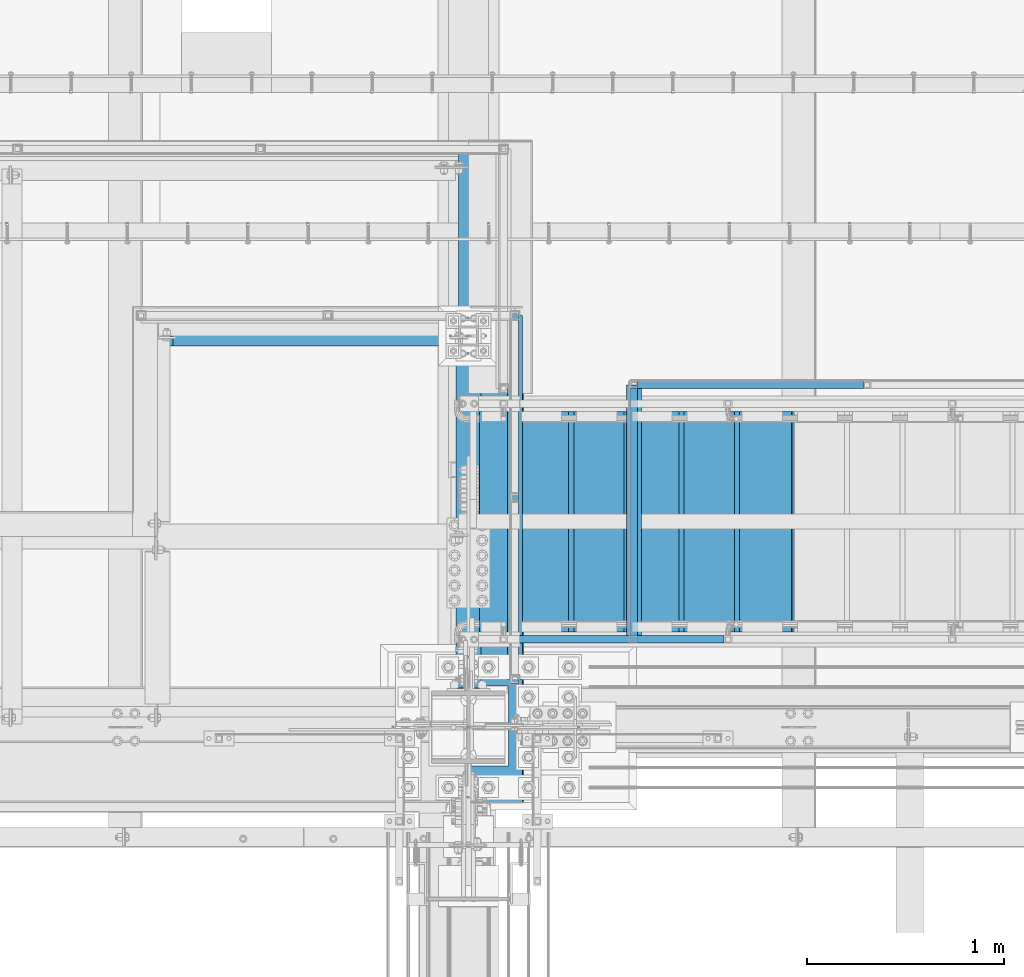
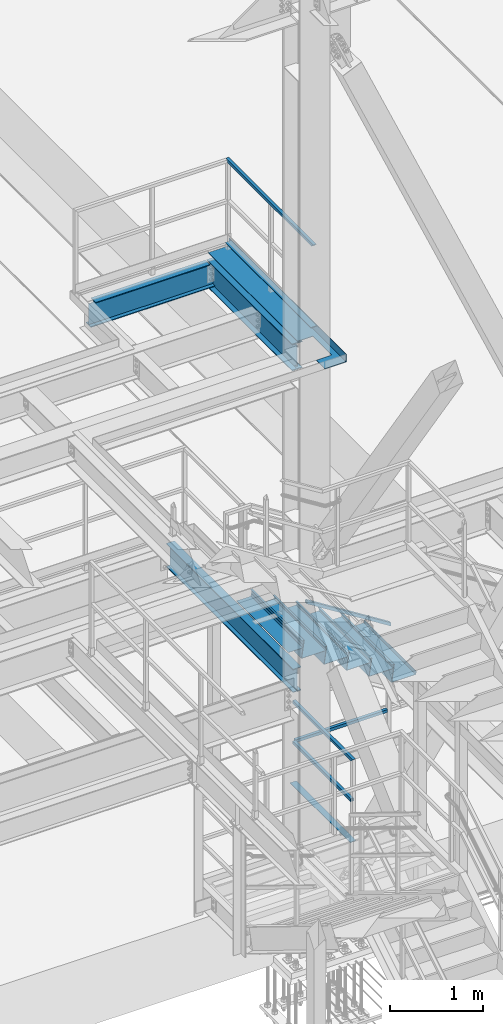
# One storey, part 1786 of 3843: 16 beams, 1 member, 9 elements without a shape of their own.
"""IFC2X3 building model written with IfcOpenShell, lengths in millimetres."""

from ifc_helpers import new_model, si_unit, frame, origin_with_axes, place, context, subcontext, project, spatial, faceted_brep, material, type_object, element, aggregate, save


model = new_model("IFC2X3")

# Units and contexts
model_context = context("Model", 3, precision=1e-05, world=origin_with_axes())
body_context = subcontext(model_context, "Body", "Model", "MODEL_VIEW")
ifc_project = project(units=[si_unit("LENGTHUNIT", "METRE", prefix="MILLI"), si_unit("AREAUNIT", "SQUARE_METRE"), si_unit("VOLUMEUNIT", "CUBIC_METRE"), si_unit("MASSUNIT", "GRAM", prefix="KILO"), si_unit("TIMEUNIT", "SECOND"), si_unit("PLANEANGLEUNIT", "RADIAN"), si_unit("SOLIDANGLEUNIT", "STERADIAN"), si_unit("THERMODYNAMICTEMPERATUREUNIT", "DEGREE_CELSIUS"), si_unit("LUMINOUSINTENSITYUNIT", "LUMEN")], contexts=[model_context])

# Site, building, storey
site_placement = place(None, origin_with_axes())
site = spatial("IfcSite", under=ifc_project, at=site_placement, CompositionType="ELEMENT")
building_placement = place(site_placement, origin_with_axes())
building = spatial("IfcBuilding", under=site, at=building_placement, Name="Undefined", CompositionType="ELEMENT")
storey_placement = place(building_placement, origin_with_axes())
storey = spatial("IfcBuildingStorey", under=building, at=storey_placement, Name="Undefined", CompositionType="ELEMENT", Elevation=0.0)

# Assembly, beam
assembly_1_placement = place(storey_placement, origin_with_axes())
assembly_1 = element("IfcElementAssembly", 1, at=assembly_1_placement, inside=storey, Name="RAIL", AssemblyPlace="NOTDEFINED", PredefinedType="RIGID_FRAME")
ifc_material_1 = material()
beam_type_1 = type_object("IfcBeamType", Name="HSS1-1/2X1-1/2X1/4", PredefinedType="NOTDEFINED")
beam_1_placement = place(assembly_1_placement, frame((56165.7500122071, 27720.9247854388, 38633.3999983618), z_axis=(0.0, 0.0, -1.0), x_axis=(0.0, -1.0, 0.0)))
beam_1 = element("IfcBeam", 2, at=beam_1_placement, type_object=beam_type_1, material=ifc_material_1, Name="RAIL", ObjectType="HSS1-1/2X1-1/2X1/4", context=body_context, shape_type="Brep", body=[
    faceted_brep([(6.34999999999854, 12.6999993299978, -12.6999993299978), (6.34999999999854, -12.6999993299978, -12.6999993299978), (1876.42478706376, -12.6999993299978, -12.6999993299978), (1876.42478706376, 12.6999993299978, -12.6999993299978), (31.7500007135677, -12.6999993300014, 12.6999993299978), (1851.02478840376, -12.6999993299978, 12.6999993299978), (31.7500007135677, 12.6999993300014, 12.6999993299978), (1851.02478840376, 12.6999993299978, 12.6999993299978), (0.0, 19.0500000000029, -19.0499999999993), (38.0999984699883, 19.0499992350015, 19.0499992350015), (1844.67478849876, 19.0499992350015, 19.0499992350015), (1882.77478696876, 19.0499992350015, -19.0499992350015), (38.0999984699883, -19.0499992350015, 19.0499992350015), (1844.67478849876, -19.0499992350015, 19.0499992350015), (0.0, -19.0499992350015, -19.0499992350015), (1882.77478696876, -19.0499992350015, -19.0499992350015)], [[[0, 1, 2, 3]], [[1, 4, 5, 2]], [[4, 6, 7, 5]], [[6, 0, 3, 7]], [[8, 9, 10, 11]], [[9, 12, 13, 10]], [[12, 14, 15, 13]], [[14, 8, 11, 15]], [[13, 15, 11, 10], [5, 7, 3, 2]], [[14, 12, 9, 8], [6, 4, 1, 0]]]),
])
aggregate(assembly_1, [beam_1])

# Assembly, beams
assembly_2_placement = place(storey_placement, origin_with_axes())
assembly_2 = element("IfcElementAssembly", 3, at=assembly_2_placement, inside=storey, Name="RAIL", AssemblyPlace="NOTDEFINED", PredefinedType="RIGID_FRAME")
beam_2_placement = place(assembly_2_placement, frame((56769.0000000085, 26060.4000000594, 31013.3999999739), z_axis=(0.0, 0.0, 1.0), x_axis=(0.0, 1.0, 0.0)))
beam_2 = element("IfcBeam", 4, at=beam_2_placement, type_object=beam_type_1, material=ifc_material_1, Name="RAIL", ObjectType="HSS1-1/2X1-1/2X1/4", context=body_context, shape_type="Brep", body=[
    faceted_brep([(1269.99999999064, -19.0499999999956, 19.0499992350015), (1269.99999999064, -19.0499992350015, -19.0499992350015), (1269.99999999064, 19.0499992350015, -19.0499992350015), (1269.99999999064, 19.0499992350015, 19.0499992350015), (1269.99999999064, -12.6999993299978, 12.6999993300014), (1269.99999999064, 12.6999993299978, 12.6999993300014), (1269.99999999064, 12.6999993299978, -12.6999993300014), (1269.99999999064, -12.6999993299978, -12.6999993300014), (19.0499992350015, 19.0499992350015, -19.0499992350015), (19.0499992350015, 19.0499992350015, 19.0499992350015), (19.0499992350015, -19.0499992350015, 19.0499992350015), (19.0499992350015, -19.0499992350015, -19.0499992350015), (19.0499992350015, 12.6999993299978, 12.6999993299978), (19.0499992350015, -12.6999993299978, 12.6999993299978), (19.0499992350015, -12.6999993299978, -12.6999993299978), (19.0499992350015, 12.6999993299978, -12.6999993299978)], [[[0, 1, 2, 3], [4, 5, 6, 7]], [[8, 9, 3, 2]], [[9, 10, 0, 3]], [[10, 11, 1, 0]], [[11, 8, 2, 1]], [[11, 10, 9, 8], [12, 13, 14, 15]], [[14, 13, 4, 7]], [[15, 14, 7, 6]], [[12, 15, 6, 5]], [[13, 12, 5, 4]]]),
])
beam_3_placement = place(assembly_2_placement, frame((56769.0000000085, 27368.499999285, 31546.7999999739), z_axis=(0.0, 0.0, -1.0), x_axis=(0.0, -1.0, 0.0)))
beam_3 = element("IfcBeam", 5, at=beam_3_placement, type_object=beam_type_1, material=ifc_material_1, Name="RAIL", ObjectType="HSS1-1/2X1-1/2X1/4", context=body_context, shape_type="Brep", body=[
    faceted_brep([(38.0999984699883, 12.6999993299978, -12.6999993300014), (38.0999984699883, -12.6999993299978, -12.6999993300014), (1320.79999855565, -12.6999993299978, -12.6999993300014), (1320.79999855565, 12.6999993299978, -12.6999993300014), (38.0999984699883, -12.6999993299978, 12.6999993300014), (1295.39999989564, -12.6999993299978, 12.6999993300014), (38.0999984699883, 12.6999993299978, 12.6999993300014), (1295.39999989564, 12.6999993299978, 12.6999993300014), (38.0999984699883, 19.0499992350015, -19.0499992350015), (38.0999984699883, 19.0499992350015, 19.0499992350015), (1289.04999999064, 19.0499992350015, 19.0499992350015), (1327.14999846065, 19.0499992350015, -19.0499992350015), (38.0999984699883, -19.0499992350015, 19.0499992350015), (1289.04999999064, -19.0499992350015, 19.0499992350015), (38.0999984699883, -19.0499992350015, -19.0499992350015), (1327.14999846065, -19.0499992350015, -19.0499992350015)], [[[0, 1, 2, 3]], [[1, 4, 5, 2]], [[4, 6, 7, 5]], [[6, 0, 3, 7]], [[8, 9, 10, 11]], [[9, 12, 13, 10]], [[12, 14, 15, 13]], [[14, 8, 11, 15]], [[13, 15, 11, 10], [5, 7, 3, 2]], [[14, 12, 9, 8], [6, 4, 1, 0]]]),
])
beam_4_placement = place(assembly_2_placement, frame((57950.1000000016, 27349.4500000502, 31013.3999999739), z_axis=(0.0, 0.0, 1.0), x_axis=(-1.0, 0.0, 0.0)))
beam_4 = element("IfcBeam", 6, at=beam_4_placement, type_object=beam_type_1, material=ifc_material_1, Name="RAIL", ObjectType="HSS1-1/2X1-1/2X1/4", context=body_context, shape_type="Brep", body=[
    faceted_brep([(1162.04999999311, -19.0499999997628, 19.0499992350015), (1162.04999999311, -19.0499992350015, -19.0499992350015), (1162.04999999311, 19.0499992350015, -19.0499992350015), (1162.04999999311, 19.0499992350015, 19.0499992350015), (1162.04999999311, -12.6999993300014, 12.6999993300014), (1162.04999999311, 12.6999993300014, 12.6999993300014), (1162.04999999311, 12.6999993300014, -12.6999993300014), (1162.04999999311, -12.6999993300014, -12.6999993300014), (19.0499992350015, 19.0499992350015, -19.0499992350015), (19.0499992350015, 19.0499992350015, 19.0499992350015), (19.0499992350015, -19.0499992350015, 19.0499992350015), (19.0499992350015, -19.0499992350015, -19.0499992350015), (19.0499992350015, 12.6999993299978, 12.6999993299978), (19.0499992350015, -12.6999993299978, 12.6999993299978), (19.0499992350015, -12.6999993299978, -12.6999993299978), (19.0499992350015, 12.6999993299978, -12.6999993299978)], [[[0, 1, 2, 3], [4, 5, 6, 7]], [[8, 9, 3, 2]], [[9, 10, 0, 3]], [[10, 11, 1, 0]], [[11, 8, 2, 1]], [[11, 10, 9, 8], [12, 13, 14, 15]], [[14, 13, 4, 7]], [[15, 14, 7, 6]], [[12, 15, 6, 5]], [[13, 12, 5, 4]]]),
])
aggregate(assembly_2, [beam_2, beam_3, beam_4])

# Assembly, member
assembly_3_placement = place(storey_placement, origin_with_axes())
assembly_3 = element("IfcElementAssembly", 7, at=assembly_3_placement, inside=storey, Name="RAIL", AssemblyPlace="NOTDEFINED", PredefinedType="RIGID_FRAME")
member_type = type_object("IfcMemberType", Name="HSS1-1/2X1-1/2X1/4", PredefinedType="NOTDEFINED")
member_placement = place(assembly_3_placement, frame((57245.2499999772, 26060.40000005, 33163.9934658526), z_axis=(0.533450437959022, 0.0, 0.845831324935018), x_axis=(-0.845831324935018, 0.0, 0.533450437959022)))
member = element("IfcMember", 8, at=member_placement, type_object=member_type, material=ifc_material_1, Name="RAIL", ObjectType="HSS1-1/2X1-1/2X1/4", context=body_context, shape_type="Brep", body=[
    faceted_brep([(34.5367091819608, -19.0500003825, 19.0499992349214), (34.5367091819608, 19.0499992350015, 19.0499992349214), (10.507732870894, 19.0499992350015, -19.049999235016), (10.507732870894, -19.0499992350015, -19.049999235016), (30.5318796958745, -12.6999993300014, 12.699999329925), (14.5125623569802, -12.6999993300014, -12.6999993300269), (14.5125623569802, 12.6999993300014, -12.6999993300269), (30.5318796958745, 12.6999993300014, 12.699999329925), (1248.23146424039, 19.0499992350015, -19.0499992375117), (1248.23146424039, -19.0499992350015, -19.0499992375117), (1259.2424708534, -19.0499992350015, 19.0499992324476), (1259.2424708534, 19.0499992350015, 19.0499992324476), (1257.40730303832, -12.6999993300014, 12.6999993274512), (1257.40730303832, 12.6999993300014, 12.6999993274512), (1250.06663205547, 12.6999993300014, -12.6999993325153), (1250.06663205547, -12.6999993300014, -12.6999993325153)], [[[0, 1, 2, 3], [4, 5, 6, 7]], [[8, 9, 3, 2]], [[9, 10, 0, 3]], [[10, 11, 1, 0]], [[11, 8, 2, 1]], [[10, 9, 8, 11], [12, 13, 14, 15]], [[13, 12, 4, 7]], [[14, 13, 7, 6]], [[15, 14, 6, 5]], [[12, 15, 5, 4]]]),
])
aggregate(assembly_3, [member])

# Assembly, beam
assembly_4_placement = place(storey_placement, origin_with_axes())
assembly_4 = element("IfcElementAssembly", 9, at=assembly_4_placement, inside=storey, Name="ref.", AssemblyPlace="NOTDEFINED", PredefinedType="RIGID_FRAME")
ifc_material_2 = material(Name="STEEL/Steel_Undefined")
beam_type_2 = type_object("IfcBeamType", PredefinedType="NOTDEFINED")
beam_5_placement = place(assembly_4_placement, frame((56165.750012207, 25857.199997705, 37563.4249983618), z_axis=(1.0, 0.0, 0.0), x_axis=(0.0, 1.0, 0.0)))
beam_5 = element("IfcBeam", 10, at=beam_5_placement, type_object=beam_type_2, material=ifc_material_2, Name="ref.", context=body_context, shape_type="Brep", body=[
    faceted_brep([(0.0, 3.17500000000291, -38.0999999999985), (0.0, 3.17500000000291, 38.0999999999985), (1844.67478849919, 3.17500000000291, 38.0999999999985), (1844.67478849919, 3.17500000000291, -38.0999999999985), (0.0, -3.17500000000291, 38.0999999999985), (1844.67478849919, -3.17500000000291, 38.0999999999985), (0.0, -3.17500000000291, -38.0999999999985), (1844.67478849919, -3.17500000000291, -38.0999999999985)], [[[0, 1, 2, 3]], [[1, 4, 5, 2]], [[4, 6, 7, 5]], [[6, 0, 3, 7]], [[5, 7, 3, 2]], [[6, 4, 1, 0]]]),
])
aggregate(assembly_4, [beam_5])

assembly_5_placement = place(storey_placement, origin_with_axes())
assembly_5 = element("IfcElementAssembly", 11, at=assembly_5_placement, inside=storey, Name="ref.", AssemblyPlace="NOTDEFINED", PredefinedType="RIGID_FRAME")
beam_6_placement = place(assembly_5_placement, frame((56769.0000000085, 27349.45000005, 30476.8249999739), z_axis=(1.0, 0.0, 0.0), x_axis=(0.0, -1.0, 0.0)))
beam_6 = element("IfcBeam", 12, at=beam_6_placement, type_object=beam_type_2, material=ifc_material_2, Name="ref.", context=body_context, shape_type="Brep", body=[
    faceted_brep([(0.0, 3.17500000000291, -38.0999999999985), (0.0, 3.17500000000291, 38.0999999999985), (1289.04999999063, 3.17499999999927, 38.0999999999985), (1289.04999999063, 3.17499999999927, -38.0999999999985), (0.0, -3.17500000000291, 38.0999999999985), (1289.04999999063, -3.17499999999927, 38.0999999999985), (0.0, -3.17500000000291, -38.0999999999985), (1289.04999999063, -3.17499999999927, -38.0999999999985)], [[[0, 1, 2, 3]], [[1, 4, 5, 2]], [[4, 6, 7, 5]], [[6, 0, 3, 7]], [[5, 7, 3, 2]], [[6, 4, 1, 0]]]),
])
aggregate(assembly_5, [beam_6])

assembly_6_placement = place(storey_placement, origin_with_axes())
assembly_6 = element("IfcElementAssembly", 13, at=assembly_6_placement, inside=storey, Name="STAIR", AssemblyPlace="NOTDEFINED", PredefinedType="RIGID_FRAME")
ifc_material_3 = material(Name="STEEL/ASTM A1011")
beam_type_3 = type_object("IfcBeamType", PredefinedType="NOTDEFINED")
beam_7_placement = place(assembly_6_placement, frame((55987.9499999695, 26657.3000000416, 33205.7375000177), z_axis=(0.0, 1.0, 0.0), x_axis=(1.0, 0.0, 0.0)))
beam_7 = element("IfcBeam", 14, at=beam_7_placement, type_object=beam_type_3, material=ifc_material_3, Name="TREAD", context=body_context, shape_type="Brep", body=[
    faceted_brep([(0.0, -1.58750000000146, -558.799999999999), (0.0, -1.58750000000146, 558.799999999999), (0.0, 1.58750000000146, 558.799999999999), (0.0, 1.58750000000146, -558.799999999999), (179.41899566666, 1.58750000000146, 558.799999999999), (179.41899566666, 1.58750000000146, -558.799999999999), (176.704640751166, -1.58750000000146, -558.799999999999), (176.704640751166, -1.58750000000146, 558.799999999999), (185.276740617643, -35.6290960190308, 558.799999999999), (185.276740617643, -35.6290960190308, -558.799999999999), (182.140352618517, -36.1227510797107, 558.799999999999), (182.140352618517, -36.1227510797107, -558.799999999999)], [[[0, 1, 2, 3]], [[3, 2, 4, 5]], [[1, 0, 6, 7]], [[5, 4, 8, 9]], [[4, 2, 1, 7, 10, 8]], [[7, 6, 11, 10]], [[6, 0, 3, 5, 9, 11]], [[10, 11, 9, 8]]]),
])

assembly_7_placement = place(storey_placement, origin_with_axes())
assembly_7 = element("IfcElementAssembly", 15, at=assembly_7_placement, inside=storey, Name="BEAM", AssemblyPlace="NOTDEFINED", PredefinedType="RIGID_FRAME")
ifc_material_4 = material(Name="STEEL/A992")
beam_type_4 = type_object("IfcBeamType", Name="W12X19", PredefinedType="NOTDEFINED")
beam_8_placement = place(assembly_7_placement, frame((54356.0, 27597.1, 37311.0125), z_axis=(0.0, 0.0, 1.0), x_axis=(1.0, 0.0, 0.0)))
beam_8 = element("IfcBeam", 16, at=beam_8_placement, type_object=beam_type_4, material=ifc_material_4, Name="BEAM", ObjectType="W12X19", context=body_context, shape_type="Brep", body=[
    faceted_brep([(66.6750001907276, -3.17500000000291, 128.587500000001), (66.6750001907276, 3.17500000000291, 128.587500000001), (15.8750000000146, 3.17500000000291, 128.587500001042), (15.8750000000146, -3.17500000000291, 128.587500001042), (71.535079708774, -3.17500000000291, 129.554229922593), (71.535079708774, 3.17500000000291, 129.554229922593), (75.6552561769277, -3.17500000000291, 132.307243823067), (75.6552561769277, 3.17500000000291, 132.307243823067), (78.4082700774052, -3.17500000000291, 136.42742029122), (78.4082700774052, 3.17500000000291, 136.42742029122), (79.3749999999927, -3.17500000000291, 141.287499809267), (79.3749999999927, 3.17500000000291, 141.287499809267), (79.3750000000073, -50.7999999999993, 153.891067210468), (79.3749999999927, 50.8000000000029, 153.987500000003), (79.3749999999927, 50.8000000000029, 144.462500000001), (79.3749999999927, 3.17500000000291, 144.462500000001), (79.3749999999927, -3.17500000000291, 144.462500000001), (79.3749999999927, -50.8000000000029, 144.462500000001), (15.8749999999927, -3.17500000000291, -144.462500000001), (15.8749999999927, -50.8000000000029, -144.462500000001), (1558.925, -50.7999999999993, -144.462500000001), (1558.925, -3.17499999999927, -144.462500000001), (15.8749999999927, -50.8000000000029, -153.987500000003), (1558.925, -50.7999999999993, -153.987500000003), (15.8749999999927, 50.8000000000029, -153.987500000003), (1558.925, 50.7999999999993, -153.987500000003), (15.8749999999927, 50.8000000000029, -144.462500000001), (1558.925, 50.7999999999993, -144.462500000001), (15.8749999999927, 3.17500000000291, -144.462500000001), (1558.925, 3.17499999999927, -144.462500000001), (1558.925, -3.17499999999927, 115.887499999997), (1558.925, -3.17499999999927, -114.712500000001), (1558.925, 3.17499999999927, 128.587500000001), (1558.925, -3.17499999999927, 128.587500000001), (1508.12499980927, 3.17499999999927, 128.587500000001), (1508.12499980927, -3.17499999999927, 128.587500000001), (1503.26492029122, 3.17499999999927, 129.554229922593), (1503.26492029122, -3.17499999999927, 129.554229922593), (1499.14474382307, 3.17499999999927, 132.307243823067), (1499.14474382307, -3.17499999999927, 132.307243823067), (1496.39172992259, 3.17499999999927, 136.42742029122), (1496.39172992259, -3.17499999999927, 136.42742029122), (1495.425, 3.17499999999927, 141.287499809267), (1495.425, -3.17499999999927, 141.287499809267), (1495.425, -50.7999999999993, 153.987500000003), (1495.425, -50.7999999999993, 144.462500000001), (1495.425, -3.17499999999927, 144.462500000001), (1495.425, 3.17499999999927, 144.462500000001), (1495.425, 50.7999999999993, 144.462500000001), (1495.425, 50.7999999999993, 153.987500000003), (15.8750000000073, -3.17499999999927, 115.887499999997), (15.8750000000073, -3.17499999999927, -114.712500000001)], [[[0, 1, 2, 3]], [[4, 5, 1, 0]], [[6, 7, 5, 4]], [[8, 9, 7, 6]], [[10, 11, 9, 8]], [[12, 13, 14, 15, 11, 10, 16, 17]], [[18, 19, 20, 21]], [[19, 22, 23, 20]], [[22, 24, 25, 23]], [[24, 26, 27, 25]], [[26, 28, 29, 27]], [[30, 31, 21, 20, 23, 25, 27, 29, 32, 33]], [[33, 32, 34, 35]], [[35, 34, 36, 37]], [[37, 36, 38, 39]], [[39, 38, 40, 41]], [[41, 40, 42, 43]], [[44, 45, 46, 43, 42, 47, 48, 49]], [[45, 44, 12, 17]], [[46, 45, 17, 16]], [[8, 6, 4, 0, 3, 50, 51, 18, 21, 31, 30, 33, 35, 37, 39, 41, 43, 46, 16, 10]], [[28, 26, 24, 22, 19, 18, 51, 50, 3, 2]], [[47, 42, 40, 38, 36, 34, 32, 29, 28, 2, 1, 5, 7, 9, 11, 15]], [[48, 47, 15, 14]], [[49, 48, 14, 13]], [[44, 49, 13, 12]]]),
])
aggregate(assembly_7, [beam_8])

assembly_8_placement = place(storey_placement, origin_with_axes())
assembly_8 = element("IfcElementAssembly", 17, at=assembly_8_placement, inside=storey, Name="BEAM", AssemblyPlace="NOTDEFINED", PredefinedType="RIGID_FRAME")
beam_9_placement = place(assembly_8_placement, frame((55930.8, 25615.8999999464, 33043.8124999995), z_axis=(0.0, 0.0, 1.0), x_axis=(0.0, 1.0, 0.0)))
beam_9 = element("IfcBeam", 18, at=beam_9_placement, type_object=beam_type_4, material=ifc_material_4, Name="BEAM", ObjectType="W12X19", context=body_context, shape_type="Brep", body=[
    faceted_brep([(196.849999999973, -50.8000000000029, -144.462500000001), (196.849999999973, -50.8000000000029, -153.987500000003), (2921.00000005052, -50.8000000000029, -153.987500000003), (2921.00000005052, -50.8000000000029, -144.462500000001), (196.849999999973, -3.17500000000291, -144.462500000001), (2921.00000005052, -3.17500000000291, -144.462500000001), (196.849999999973, -3.17500000000291, 144.462500000001), (2921.00000005052, -3.17500000000291, 144.462500000001), (196.849999999973, -50.8000000000029, 144.462500000001), (2921.00000005052, -50.8000000000029, 144.462500000001), (196.849999999973, -50.8000000000029, 153.987500000003), (2921.00000005052, -50.8000000000029, 153.987500000003), (196.849999999973, 50.8000000000029, 153.987500000003), (2921.00000005052, 50.8000000000029, 153.987500000003), (196.849999999973, 50.8000000000029, 144.462500000001), (2921.00000005052, 50.8000000000029, 144.462500000001), (196.849999999973, 3.17500000000291, 144.462500000001), (2921.00000005052, 3.17500000000291, 144.462500000001), (196.849999999973, 3.17500000000291, -144.462500000001), (2921.00000005052, 3.17500000000291, -144.462500000001), (196.849999999973, 50.8000000000029, -144.462500000001), (2921.00000005052, 50.8000000000029, -144.462500000001), (196.849999999973, 50.8000000000029, -153.987500000003), (2921.00000005052, 50.8000000000029, -153.987500000003)], [[[0, 1, 2, 3]], [[4, 0, 3, 5]], [[6, 4, 5, 7]], [[8, 6, 7, 9]], [[10, 8, 9, 11]], [[12, 10, 11, 13]], [[14, 12, 13, 15]], [[16, 14, 15, 17]], [[18, 16, 17, 19]], [[20, 18, 19, 21]], [[1, 0, 4, 6, 8, 10, 12, 14, 16, 18, 20, 22]], [[1, 22, 23, 2]], [[19, 17, 15, 13, 11, 9, 7, 5, 3, 2, 23, 21]], [[22, 20, 21, 23]]]),
])
aggregate(assembly_8, [beam_9])

# Beam
beam_type_5 = type_object("IfcBeamType", PredefinedType="NOTDEFINED")
beam_10_placement = place(assembly_6_placement, frame((56159.4000000094, 26657.3000000521, 33297.812499978), z_axis=(0.0, 1.0, 0.0), x_axis=(1.0, 0.0, 0.0)))
beam_10 = element("IfcBeam", 19, at=beam_10_placement, type_object=beam_type_5, material=ifc_material_3, Name="TREAD", context=body_context, shape_type="Brep", body=[
    faceted_brep([(0.0, -1.58750000000146, -558.799999999999), (0.0, -1.58750000000146, 558.799999999999), (0.0, 1.58750000000146, 558.799999999999), (0.0, 1.58750000000146, -558.799999999999), (21.7345275870466, 1.58750000000146, 558.799999999999), (21.7345275870466, 1.58750000000146, -558.799999999999), (25.3999999999942, -1.58750000000146, -558.799999999999), (25.3999999999942, -1.58750000000146, 558.799999999999), (-10.9879949354727, 228.599999999999, 558.799999999999), (-10.9879949354727, 228.599999999999, -558.799999999999), (-7.32252251826139, 225.424999999996, -558.799999999999), (-7.32252251826139, 225.424999999996, 558.799999999999), (293.812005064523, 228.599999999999, 558.799999999999), (293.812005064523, 228.599999999999, -558.799999999999), (291.061847962628, 225.424999999996, -558.799999999999), (291.061847962628, 225.424999999996, 558.799999999999), (299.640080752673, 188.167724913437, 558.799999999999), (299.640080752673, 188.167724913437, -558.799999999999), (296.49755982936, 187.714748924496, 558.799999999999), (296.49755982936, 187.714748924496, -558.799999999999)], [[[0, 1, 2, 3]], [[3, 2, 4, 5]], [[1, 0, 6, 7]], [[5, 4, 8, 9]], [[7, 6, 10, 11]], [[9, 8, 12, 13]], [[11, 10, 14, 15]], [[13, 12, 16, 17]], [[12, 8, 4, 2, 1, 7, 11, 15, 18, 16]], [[15, 14, 19, 18]], [[14, 10, 6, 0, 3, 5, 9, 13, 17, 19]], [[18, 19, 17, 16]]]),
])

beam_11_placement = place(assembly_6_placement, frame((56438.8000000093, 26657.30000005, 33121.599999978), z_axis=(0.0, 1.0, 0.0), x_axis=(1.0, 0.0, 0.0)))
beam_11 = element("IfcBeam", 20, at=beam_11_placement, type_object=beam_type_5, material=ifc_material_3, Name="TREAD", context=body_context, shape_type="Brep", body=[
    faceted_brep([(0.0, -1.58750000000146, -558.799999999999), (0.0, -1.58750000000146, 558.799999999999), (0.0, 1.58750000000146, 558.799999999999), (0.0, 1.58750000000146, -558.799999999999), (21.7345275870466, 1.58750000000146, 558.799999999999), (21.7345275870466, 1.58750000000146, -558.799999999999), (25.3999999999942, -1.58750000000146, -558.799999999999), (25.3999999999942, -1.58750000000146, 558.799999999999), (-10.9879949354727, 228.599999999999, 558.799999999999), (-10.9879949354727, 228.599999999999, -558.799999999999), (-7.32252251826139, 225.424999999996, -558.799999999999), (-7.32252251826139, 225.424999999996, 558.799999999999), (293.812005064523, 228.599999999999, 558.799999999999), (293.812005064523, 228.599999999999, -558.799999999999), (291.061847962628, 225.424999999996, -558.799999999999), (291.061847962628, 225.424999999996, 558.799999999999), (299.640080752673, 188.167724913437, 558.799999999999), (299.640080752673, 188.167724913437, -558.799999999999), (296.49755982936, 187.714748924496, 558.799999999999), (296.49755982936, 187.714748924496, -558.799999999999)], [[[0, 1, 2, 3]], [[3, 2, 4, 5]], [[1, 0, 6, 7]], [[5, 4, 8, 9]], [[7, 6, 10, 11]], [[9, 8, 12, 13]], [[11, 10, 14, 15]], [[13, 12, 16, 17]], [[12, 8, 4, 2, 1, 7, 11, 15, 18, 16]], [[15, 14, 19, 18]], [[14, 10, 6, 0, 3, 5, 9, 13, 17, 19]], [[18, 19, 17, 16]]]),
])

beam_12_placement = place(assembly_6_placement, frame((56718.2000000094, 26657.300000048, 32945.387499978), z_axis=(0.0, 1.0, 0.0), x_axis=(1.0, 0.0, 0.0)))
beam_12 = element("IfcBeam", 21, at=beam_12_placement, type_object=beam_type_5, material=ifc_material_3, Name="TREAD", context=body_context, shape_type="Brep", body=[
    faceted_brep([(0.0, -1.58750000000146, -558.799999999999), (0.0, -1.58750000000146, 558.799999999999), (0.0, 1.58750000000146, 558.799999999999), (0.0, 1.58750000000146, -558.799999999999), (21.7345275870466, 1.58750000000146, 558.799999999999), (21.7345275870466, 1.58750000000146, -558.799999999999), (25.3999999999942, -1.58750000000146, -558.799999999999), (25.3999999999942, -1.58750000000146, 558.799999999999), (-10.9879949354727, 228.599999999999, 558.799999999999), (-10.9879949354727, 228.599999999999, -558.799999999999), (-7.32252251826139, 225.424999999996, -558.799999999999), (-7.32252251826139, 225.424999999996, 558.799999999999), (293.812005064523, 228.599999999999, 558.799999999999), (293.812005064523, 228.599999999999, -558.799999999999), (291.061847962628, 225.424999999996, -558.799999999999), (291.061847962628, 225.424999999996, 558.799999999999), (299.640080752673, 188.167724913437, 558.799999999999), (299.640080752673, 188.167724913437, -558.799999999999), (296.49755982936, 187.714748924496, 558.799999999999), (296.49755982936, 187.714748924496, -558.799999999999)], [[[0, 1, 2, 3]], [[3, 2, 4, 5]], [[1, 0, 6, 7]], [[5, 4, 8, 9]], [[7, 6, 10, 11]], [[9, 8, 12, 13]], [[11, 10, 14, 15]], [[13, 12, 16, 17]], [[12, 8, 4, 2, 1, 7, 11, 15, 18, 16]], [[15, 14, 19, 18]], [[14, 10, 6, 0, 3, 5, 9, 13, 17, 19]], [[18, 19, 17, 16]]]),
])

beam_13_placement = place(assembly_6_placement, frame((56997.6000000095, 26657.3000000451, 32769.1749999779), z_axis=(0.0, 1.0, 0.0), x_axis=(1.0, 0.0, 0.0)))
beam_13 = element("IfcBeam", 22, at=beam_13_placement, type_object=beam_type_5, material=ifc_material_3, Name="TREAD", context=body_context, shape_type="Brep", body=[
    faceted_brep([(0.0, -1.58750000000146, -558.799999999999), (0.0, -1.58750000000146, 558.799999999999), (0.0, 1.58750000000146, 558.799999999999), (0.0, 1.58750000000146, -558.799999999999), (21.7345275870466, 1.58750000000146, 558.799999999999), (21.7345275870466, 1.58750000000146, -558.799999999999), (25.3999999999942, -1.58750000000146, -558.799999999999), (25.3999999999942, -1.58750000000146, 558.799999999999), (-10.9879949354727, 228.599999999999, 558.799999999999), (-10.9879949354727, 228.599999999999, -558.799999999999), (-7.32252251826139, 225.424999999996, -558.799999999999), (-7.32252251826139, 225.424999999996, 558.799999999999), (293.812005064523, 228.599999999999, 558.799999999999), (293.812005064523, 228.599999999999, -558.799999999999), (291.061847962628, 225.424999999996, -558.799999999999), (291.061847962628, 225.424999999996, 558.799999999999), (299.640080752673, 188.167724913437, 558.799999999999), (299.640080752673, 188.167724913437, -558.799999999999), (296.49755982936, 187.714748924496, 558.799999999999), (296.49755982936, 187.714748924496, -558.799999999999)], [[[0, 1, 2, 3]], [[3, 2, 4, 5]], [[1, 0, 6, 7]], [[5, 4, 8, 9]], [[7, 6, 10, 11]], [[9, 8, 12, 13]], [[11, 10, 14, 15]], [[13, 12, 16, 17]], [[12, 8, 4, 2, 1, 7, 11, 15, 18, 16]], [[15, 14, 19, 18]], [[14, 10, 6, 0, 3, 5, 9, 13, 17, 19]], [[18, 19, 17, 16]]]),
])

beam_14_placement = place(assembly_6_placement, frame((57277.0000000107, 26657.3000000437, 32592.9624999799), z_axis=(0.0, 1.0, 0.0), x_axis=(1.0, 0.0, 0.0)))
beam_14 = element("IfcBeam", 23, at=beam_14_placement, type_object=beam_type_5, material=ifc_material_3, Name="TREAD", context=body_context, shape_type="Brep", body=[
    faceted_brep([(0.0, -1.58750000000146, -558.799999999999), (0.0, -1.58750000000146, 558.799999999999), (0.0, 1.58750000000146, 558.799999999999), (0.0, 1.58750000000146, -558.799999999999), (21.7345275870466, 1.58750000000146, 558.799999999999), (21.7345275870466, 1.58750000000146, -558.799999999999), (25.3999999999942, -1.58750000000146, -558.799999999999), (25.3999999999942, -1.58750000000146, 558.799999999999), (-10.9879949354727, 228.599999999999, 558.799999999999), (-10.9879949354727, 228.599999999999, -558.799999999999), (-7.32252251826139, 225.424999999996, -558.799999999999), (-7.32252251826139, 225.424999999996, 558.799999999999), (293.812005064523, 228.599999999999, 558.799999999999), (293.812005064523, 228.599999999999, -558.799999999999), (291.061847962628, 225.424999999996, -558.799999999999), (291.061847962628, 225.424999999996, 558.799999999999), (299.640080752673, 188.167724913437, 558.799999999999), (299.640080752673, 188.167724913437, -558.799999999999), (296.49755982936, 187.714748924496, 558.799999999999), (296.49755982936, 187.714748924496, -558.799999999999)], [[[0, 1, 2, 3]], [[3, 2, 4, 5]], [[1, 0, 6, 7]], [[5, 4, 8, 9]], [[7, 6, 10, 11]], [[9, 8, 12, 13]], [[11, 10, 14, 15]], [[13, 12, 16, 17]], [[12, 8, 4, 2, 1, 7, 11, 15, 18, 16]], [[15, 14, 19, 18]], [[14, 10, 6, 0, 3, 5, 9, 13, 17, 19]], [[18, 19, 17, 16]]]),
])

aggregate(assembly_6, [beam_7, beam_10, beam_11, beam_12, beam_13, beam_14])

# Assembly, beams
assembly_9_placement = place(storey_placement, origin_with_axes())
assembly_9 = element("IfcElementAssembly", 24, at=assembly_9_placement, inside=storey, Name="BEAM", AssemblyPlace="NOTDEFINED", PredefinedType="RIGID_FRAME")
ifc_material_5 = material(Name="STEEL/A36")
beam_type_6 = type_object("IfcBeamType", PredefinedType="NOTDEFINED")
beam_15_placement = place(assembly_9_placement, frame((55943.5, 26490.4977862042, 37468.175), z_axis=(0.0, -1.0, 0.0), x_axis=(1.0, 0.0, 0.0)))
beam_15 = element("IfcBeam", 25, at=beam_15_placement, type_object=beam_type_6, material=ifc_material_5, Name="BENT_PLATE", context=body_context, shape_type="Brep", body=[
    faceted_brep([(190.5, -3.17500000000291, 665.047786204192), (190.5, 3.17500000000291, 665.047786204192), (0.0, 3.17500000000291, 665.047786204195), (0.0, -3.17500000000291, 665.047786204195), (190.500000000007, -3.17500000000291, 1071.44778620419), (190.500000000007, 3.17500000000291, 1071.44778620419), (0.0, -3.17500000000291, 1071.44778620419), (0.0, 3.17500000000291, 1071.44778620419), (266.700012207031, -3.17500000000291, 1255.827), (266.700012207031, -3.17500000000291, -1255.827), (266.700012207031, 98.4249984741182, -1255.827), (266.700012207031, 98.4249984741182, 1255.827), (260.350012207025, 3.17500000000291, 1255.827), (0.0, 3.17500000000291, 1255.827), (0.0, -3.17500000000291, 1255.827), (260.350012207025, 98.4249984741182, 1255.827), (260.350012207025, 3.17500000000291, -1255.827), (260.350012207025, 98.4249984741182, -1255.827), (0.0, -3.17500000000291, -1255.827), (0.0, 3.17500000000291, -1255.827)], [[[0, 1, 2, 3]], [[4, 5, 1, 0]], [[6, 7, 5, 4]], [[8, 9, 10, 11]], [[12, 13, 14, 8, 11, 15]], [[16, 12, 15, 17]], [[11, 10, 17, 15]], [[9, 18, 19, 16, 17, 10]], [[19, 18, 3, 2]], [[13, 12, 16, 19, 2, 1, 5, 7]], [[14, 13, 7, 6]], [[3, 18, 9, 8, 14, 6, 4, 0]]]),
])
beam_type_7 = type_object("IfcBeamType", Name="W14X22", PredefinedType="NOTDEFINED")
beam_16_placement = place(assembly_9_placement, frame((55930.8, 25615.9, 37290.375), z_axis=(0.0, 0.0, 1.0), x_axis=(0.0, 1.0, 0.0)))
beam_16 = element("IfcBeam", 26, at=beam_16_placement, type_object=beam_type_7, material=ifc_material_4, Name="BEAM", ObjectType="W14X22", context=body_context, shape_type="Brep", body=[
    faceted_brep([(198.257595234427, -63.5, 174.625), (198.257595234427, 63.5, 174.625), (193.674999999999, 63.5, 166.6875), (193.674999999999, 3.17500000000291, 166.6875), (193.674999999999, -3.17500000000291, 166.6875), (193.674999999999, -63.5, 166.6875), (2032.0, 3.17500000000291, -166.6875), (2032.0, 63.5, -166.6875), (198.257630065469, 63.5, -166.6875), (198.257630065469, 3.17500000000291, -166.6875), (2032.0, -63.5, -174.625), (2032.0, -63.5, -166.6875), (198.257630065469, -63.5, -166.6875), (193.674999999999, -63.5, -174.625), (2032.0, 63.5, -174.625), (193.674999999999, 63.5, -174.625), (2032.0, 3.17500000000291, 166.6875), (2032.0, 63.5, 166.6875), (2032.0, 63.5, 174.625), (2032.0, -63.5, 174.625), (2032.0, -63.5, 166.6875), (2032.0, -3.17500000000291, 166.6875), (2032.0, -3.17500000000291, -166.6875), (193.674999999999, 3.17500000000291, 166.290499832154), (193.674999999999, -3.17500000000291, 166.290499832154), (206.375000762946, 3.17500000000291, 166.290499496463), (206.375000762946, -3.17500000000291, 166.290499496463), (234.149096606241, 3.17500000000291, 156.634265469154), (234.149096606241, -3.17500000000291, 156.634265469154), (238.458613938903, 3.17500000000291, 153.588154207799), (238.458613938903, -3.17500000000291, 153.588154207799), (240.485007542575, 3.17500000000291, 148.715325212237), (240.485007542575, -3.17500000000291, 148.715325212237), (239.60621994832, 3.17500000000291, 143.511627890024), (239.60621994832, -3.17500000000291, 143.511627890024), (236.092019273066, 3.17500000000291, 139.57448081745), (236.092019273066, -3.17500000000291, 139.57448081745), (231.021186447342, 3.17500000000291, 138.112500000003), (231.021186447342, -3.17500000000291, 138.112500000003), (196.850000000006, 3.17500000000291, 138.112500000003), (196.850000000006, -3.17500000000291, 138.112500000003), (196.850000000006, 3.17500000000291, -138.112500000003), (196.850000000006, -3.17500000000291, -138.112500000003), (229.712187856159, 3.17500000000291, -138.112500000003), (229.712187856159, -3.17500000000291, -138.112500000003), (234.783020658339, 3.17500000000291, -139.57448080265), (234.783020658339, -3.17500000000291, -139.57448080265), (238.297221333043, 3.17500000000291, -143.511627839893), (238.297221333043, -3.17500000000291, -143.511627839893), (239.176008960832, 3.17500000000291, -148.715325129342), (239.176008960832, -3.17500000000291, -148.715325129342), (237.14961541722, 3.17500000000291, -153.588154120938), (237.14961541722, -3.17500000000291, -153.588154120938), (232.840098146404, 3.17500000000291, -156.634265423483), (232.840098146404, -3.17500000000291, -156.634265423483), (205.066003479009, 3.17500000000291, -166.290499496463), (205.066003479009, -3.17500000000291, -166.290499496463), (198.48681539873, 3.17500000000291, -166.2904996832), (198.48681539873, -3.17500000000291, -166.2904996832), (198.257630065469, -3.17500000000291, -166.6875)], [[[0, 1, 2, 3, 4, 5]], [[6, 7, 8, 9]], [[10, 11, 12, 13]], [[14, 10, 13, 15]], [[7, 14, 15, 8]], [[6, 16, 17, 18, 19, 20, 21, 22, 11, 10, 14, 7]], [[20, 19, 0, 5]], [[21, 20, 5, 4]], [[23, 24, 4, 3]], [[25, 26, 24, 23]], [[26, 25, 27, 28]], [[28, 27, 29, 30]], [[30, 29, 31, 32]], [[32, 31, 33, 34]], [[34, 33, 35, 36]], [[36, 35, 37, 38]], [[38, 37, 39, 40]], [[40, 39, 41, 42]], [[43, 44, 42, 41]], [[44, 43, 45, 46]], [[46, 45, 47, 48]], [[48, 47, 49, 50]], [[50, 49, 51, 52]], [[52, 51, 53, 54]], [[54, 53, 55, 56]], [[56, 55, 57, 58]], [[22, 21, 4, 24, 26, 28, 30, 32, 34, 36, 38, 40, 42, 44, 46, 48, 50, 52, 54, 56, 58, 59]], [[11, 22, 59, 12]], [[58, 57, 9, 8, 15, 13, 12, 59]], [[55, 53, 51, 49, 47, 45, 43, 41, 39, 37, 35, 33, 31, 29, 27, 25, 23, 3, 16, 6, 9, 57]], [[17, 16, 3, 2]], [[18, 17, 2, 1]], [[19, 18, 1, 0]]]),
])
aggregate(assembly_9, [beam_15, beam_16])

save(model, "model.ifc")
